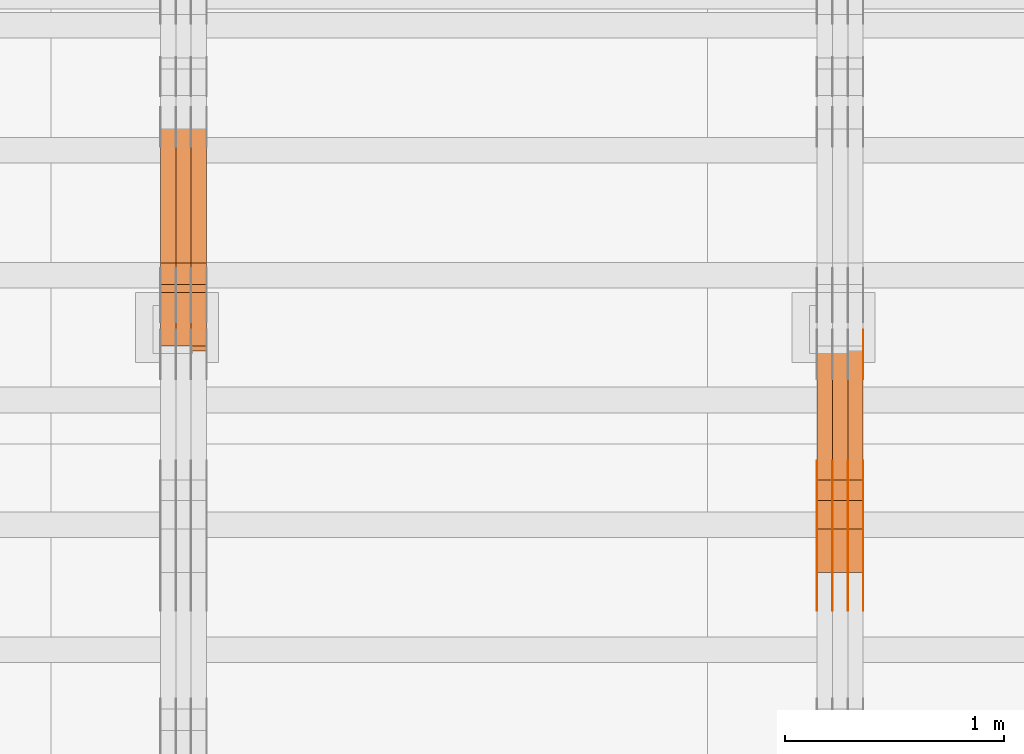
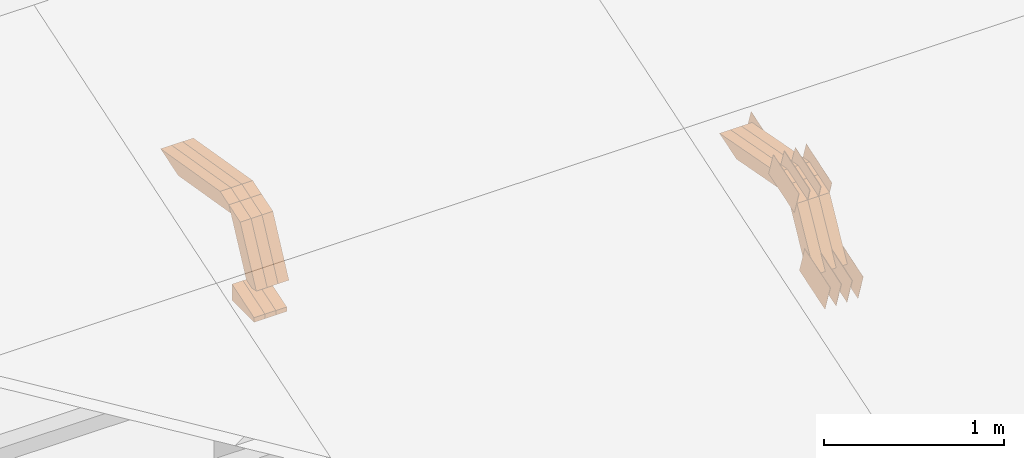
# One storey, part 154 of 385: 28 proxies.
"""IFC2X3 building model written with IfcOpenShell, lengths in millimetres."""

from ifc_helpers import new_model, entity, si_unit, converted_unit, derived_unit, direction, frame, origin, place, context, subcontext, project, spatial, polyline, outline, extrude, source, transform, mapped, material, type_object, type_shapes, element, save


model = new_model("IFC2X3")

# Units and contexts
model_context = context("Model", 3, precision=0.01, world=origin(), true_north=direction((6.12303176911189e-17, 1.0)))
body_context = subcontext(model_context, "Body", "Model", "MODEL_VIEW")
ifc_project = project(units=[si_unit("LENGTHUNIT", "METRE", prefix="MILLI"), si_unit("AREAUNIT", "SQUARE_METRE"), si_unit("VOLUMEUNIT", "CUBIC_METRE"), converted_unit("PLANEANGLEUNIT", "DEGREE", entity("IfcRatioMeasure", 0.0174532925199433), si_unit("PLANEANGLEUNIT", "RADIAN"), dimensions=[0, 0, 0, 0, 0, 0, 0]), si_unit("MASSUNIT", "GRAM", prefix="KILO"), derived_unit("MASSDENSITYUNIT", [(si_unit("MASSUNIT", "GRAM", prefix="KILO"), 1), (si_unit("LENGTHUNIT", "METRE"), -3)]), si_unit("TIMEUNIT", "SECOND"), si_unit("FREQUENCYUNIT", "HERTZ"), si_unit("THERMODYNAMICTEMPERATUREUNIT", "DEGREE_CELSIUS"), derived_unit("THERMALTRANSMITTANCEUNIT", [(si_unit("MASSUNIT", "GRAM", prefix="KILO"), 1), (si_unit("THERMODYNAMICTEMPERATUREUNIT", "KELVIN"), -1), (si_unit("TIMEUNIT", "SECOND"), -3)]), derived_unit("VOLUMETRICFLOWRATEUNIT", [(si_unit("LENGTHUNIT", "METRE"), 3), (si_unit("TIMEUNIT", "SECOND"), -1)]), si_unit("ELECTRICCURRENTUNIT", "AMPERE"), si_unit("ELECTRICVOLTAGEUNIT", "VOLT"), si_unit("POWERUNIT", "WATT"), si_unit("FORCEUNIT", "NEWTON", prefix="KILO"), si_unit("ILLUMINANCEUNIT", "LUX"), si_unit("LUMINOUSFLUXUNIT", "LUMEN"), si_unit("LUMINOUSINTENSITYUNIT", "CANDELA"), derived_unit("USERDEFINED", [(si_unit("MASSUNIT", "GRAM", prefix="KILO"), -1), (si_unit("LENGTHUNIT", "METRE"), -2), (si_unit("TIMEUNIT", "SECOND"), 3), (si_unit("LUMINOUSFLUXUNIT", "LUMEN"), 1)]), derived_unit("LINEARVELOCITYUNIT", [(si_unit("LENGTHUNIT", "METRE"), 1), (si_unit("TIMEUNIT", "SECOND"), -1)]), si_unit("PRESSUREUNIT", "PASCAL"), derived_unit("USERDEFINED", [(si_unit("LENGTHUNIT", "METRE"), -2), (si_unit("MASSUNIT", "GRAM", prefix="KILO"), 1), (si_unit("TIMEUNIT", "SECOND"), -2)])], contexts=[model_context])

# Site, building, storey
site_placement = place(None, origin())
site = spatial("IfcSite", under=ifc_project, at=site_placement, CompositionType="ELEMENT")
building_placement = place(site_placement, origin())
building = spatial("IfcBuilding", under=site, at=building_placement, CompositionType="ELEMENT")
storey_placement = place(building_placement, origin())
storey = spatial("IfcBuildingStorey", under=building, at=storey_placement, Name="Default", CompositionType="ELEMENT", Elevation=0.0)

# Proxies
ifc_material_1 = material(Name="IfcSurfaceStyle #346184")
building_element_proxy_type_1 = type_object("IfcBuildingElementProxyType", PredefinedType="NOTDEFINED", material=ifc_material_1)
shared_shape_1 = source(origin(), body_context, "Body", "SweptSolid", [
    extrude(outline(polyline([(-149.99966632326, -95.9999759039407), (149.999881095801, -95.9999759039407), (150.000557367591, 95.9999759039407), (-150.000772140132, 95.9999759039406), (-149.99966632326, -95.9999759039407)])), frame((150.000557367591, 96.0004291135906, 0.0), z_axis=(0.0, 0.0, 1.0), x_axis=(-1.0, 0.0, 0.0)), (0.0, 0.0, 1.0), 1.29999999999999),
])
type_shapes(building_element_proxy_type_1, [shared_shape_1])
proxy_1_placement = place(building_placement, frame((27386.3, 10934.7734375, 2766.8759765625), z_axis=(-1.0, 0.0, 0.0), x_axis=(0.0, 0.951056516295124, 0.309016994375039)))
element("IfcBuildingElementProxy", 1, at=proxy_1_placement, inside=storey, type_object=building_element_proxy_type_1, material=ifc_material_1, context=body_context, shape_type="MappedRepresentation", body=[
    mapped(shared_shape_1, transform((0.0, 0.0, 0.0), scale=1.0)),
])
ifc_material_2 = material(Name="IfcSurfaceStyle #346127")
building_element_proxy_type_2 = type_object("IfcBuildingElementProxyType", PredefinedType="NOTDEFINED", material=ifc_material_2)
shared_shape_2 = source(origin(), body_context, "Body", "SweptSolid", [
    extrude(outline(polyline([(-149.99966632326, -95.9999759039407), (149.999881095801, -95.9999759039407), (150.000557367591, 95.9999759039407), (-150.000772140132, 95.9999759039406), (-149.99966632326, -95.9999759039407)])), frame((150.000557367591, 96.0004291135906, 0.0), z_axis=(0.0, 0.0, 1.0), x_axis=(-1.0, 0.0, 0.0)), (0.0, 0.0, 1.0), 1.29999999999999),
])
type_shapes(building_element_proxy_type_2, [shared_shape_2])
proxy_2_placement = place(building_placement, frame((27315.0, 10934.7734375, 2766.8759765625), z_axis=(-1.0, 0.0, 0.0), x_axis=(0.0, 0.951056516295124, 0.309016994375039)))
element("IfcBuildingElementProxy", 2, at=proxy_2_placement, inside=storey, type_object=building_element_proxy_type_2, material=ifc_material_2, context=body_context, shape_type="MappedRepresentation", body=[
    mapped(shared_shape_2, transform((0.0, 0.0, 0.0), scale=1.0)),
])
ifc_material_3 = material(Name="IfcSurfaceStyle #346070")
building_element_proxy_type_3 = type_object("IfcBuildingElementProxyType", PredefinedType="NOTDEFINED", material=ifc_material_3)
shared_shape_3 = source(origin(), body_context, "Body", "SweptSolid", [
    extrude(outline(polyline([(-149.99966632326, -95.9999759039407), (149.999881095801, -95.9999759039407), (150.000557367591, 95.9999759039407), (-150.000772140132, 95.9999759039406), (-149.99966632326, -95.9999759039407)])), frame((150.000557367591, 96.0004291135906, 0.0), z_axis=(0.0, 0.0, 1.0), x_axis=(-1.0, 0.0, 0.0)), (0.0, 0.0, 1.0), 1.29999999999999),
])
type_shapes(building_element_proxy_type_3, [shared_shape_3])
proxy_3_placement = place(building_placement, frame((27316.3, 10934.7734375, 2766.8759765625), z_axis=(-1.0, 0.0, 0.0), x_axis=(0.0, 0.951056516295124, 0.309016994375039)))
element("IfcBuildingElementProxy", 3, at=proxy_3_placement, inside=storey, type_object=building_element_proxy_type_3, material=ifc_material_3, context=body_context, shape_type="MappedRepresentation", body=[
    mapped(shared_shape_3, transform((0.0, 0.0, 0.0), scale=1.0)),
])
ifc_material_4 = material(Name="IfcSurfaceStyle #346013")
building_element_proxy_type_4 = type_object("IfcBuildingElementProxyType", PredefinedType="NOTDEFINED", material=ifc_material_4)
shared_shape_4 = source(origin(), body_context, "Body", "SweptSolid", [
    extrude(outline(polyline([(-149.99966632326, -95.9999759039407), (149.999881095801, -95.9999759039407), (150.000557367591, 95.9999759039407), (-150.000772140132, 95.9999759039406), (-149.99966632326, -95.9999759039407)])), frame((150.000557367591, 96.0004291135906, 0.0), z_axis=(0.0, 0.0, 1.0), x_axis=(-1.0, 0.0, 0.0)), (0.0, 0.0, 1.0), 1.29999999999998),
])
type_shapes(building_element_proxy_type_4, [shared_shape_4])
proxy_4_placement = place(building_placement, frame((27245.0, 10934.7734375, 2766.8759765625), z_axis=(-1.0, 0.0, 0.0), x_axis=(0.0, 0.951056516295124, 0.309016994375039)))
element("IfcBuildingElementProxy", 4, at=proxy_4_placement, inside=storey, type_object=building_element_proxy_type_4, material=ifc_material_4, context=body_context, shape_type="MappedRepresentation", body=[
    mapped(shared_shape_4, transform((0.0, 0.0, 0.0), scale=1.0)),
])
ifc_material_5 = material(Name="IfcSurfaceStyle #345956")
building_element_proxy_type_5 = type_object("IfcBuildingElementProxyType", PredefinedType="NOTDEFINED", material=ifc_material_5)
shared_shape_5 = source(origin(), body_context, "Body", "SweptSolid", [
    extrude(outline(polyline([(-149.99966632326, -95.9999759039407), (149.999881095801, -95.9999759039407), (150.000557367591, 95.9999759039407), (-150.000772140132, 95.9999759039406), (-149.99966632326, -95.9999759039407)])), frame((150.000557367591, 96.0004291135906, 0.0), z_axis=(0.0, 0.0, 1.0), x_axis=(-1.0, 0.0, 0.0)), (0.0, 0.0, 1.0), 1.29999999999998),
])
type_shapes(building_element_proxy_type_5, [shared_shape_5])
proxy_5_placement = place(building_placement, frame((27246.3, 10934.7734375, 2766.8759765625), z_axis=(-1.0, 0.0, 0.0), x_axis=(0.0, 0.951056516295124, 0.309016994375039)))
element("IfcBuildingElementProxy", 5, at=proxy_5_placement, inside=storey, type_object=building_element_proxy_type_5, material=ifc_material_5, context=body_context, shape_type="MappedRepresentation", body=[
    mapped(shared_shape_5, transform((0.0, 0.0, 0.0), scale=1.0)),
])
ifc_material_6 = material(Name="IfcSurfaceStyle #345899")
building_element_proxy_type_6 = type_object("IfcBuildingElementProxyType", PredefinedType="NOTDEFINED", material=ifc_material_6)
shared_shape_6 = source(origin(), body_context, "Body", "SweptSolid", [
    extrude(outline(polyline([(-149.99966632326, -95.9999759039407), (149.999881095801, -95.9999759039407), (150.000557367591, 95.9999759039407), (-150.000772140132, 95.9999759039406), (-149.99966632326, -95.9999759039407)])), frame((150.000557367591, 96.0004291135906, 0.0), z_axis=(0.0, 0.0, 1.0), x_axis=(-1.0, 0.0, 0.0)), (0.0, 0.0, 1.0), 1.29999999999998),
])
type_shapes(building_element_proxy_type_6, [shared_shape_6])
proxy_6_placement = place(building_placement, frame((27175.0, 10934.7734375, 2766.8759765625), z_axis=(-1.0, 0.0, 0.0), x_axis=(0.0, 0.951056516295124, 0.309016994375039)))
element("IfcBuildingElementProxy", 6, at=proxy_6_placement, inside=storey, type_object=building_element_proxy_type_6, material=ifc_material_6, context=body_context, shape_type="MappedRepresentation", body=[
    mapped(shared_shape_6, transform((0.0, 0.0, 0.0), scale=1.0)),
])
ifc_material_7 = material(Name="IfcSurfaceStyle #344816")
building_element_proxy_type_7 = type_object("IfcBuildingElementProxyType", PredefinedType="NOTDEFINED", material=ifc_material_7)
shared_shape_7 = source(origin(), body_context, "Body", "SweptSolid", [
    extrude(outline(polyline([(-99.9997874178038, -60.0000528641967), (99.9998102700997, -60.0000528641967), (99.9998251396068, 60.0000528641967), (-99.9998479919027, 60.0000528641967), (-99.9997874178038, -60.0000528641967)])), frame((99.9999918898597, 60.0000528641967, 0.0), z_axis=(0.0, 0.0, 1.0), x_axis=(-1.0, 0.0, 0.0)), (0.0, 0.0, 1.0), 1.3),
])
type_shapes(building_element_proxy_type_7, [shared_shape_7])
proxy_7_placement = place(building_placement, frame((27386.3, 11991.9568177725, 3072.52282247925), z_axis=(-1.0, 0.0, 0.0), x_axis=(0.0, 0.951056516295124, 0.309016994375039)))
element("IfcBuildingElementProxy", 7, at=proxy_7_placement, inside=storey, type_object=building_element_proxy_type_7, material=ifc_material_7, context=body_context, shape_type="MappedRepresentation", body=[
    mapped(shared_shape_7, transform((0.0, 0.0, 0.0), scale=1.0)),
])
ifc_material_8 = material(Name="IfcSurfaceStyle #336608")
building_element_proxy_type_8 = type_object("IfcBuildingElementProxyType", PredefinedType="NOTDEFINED", material=ifc_material_8)
shared_shape_8 = source(origin(), body_context, "Body", "SweptSolid", [
    extrude(outline(polyline([(-150.000273478628, -84.0002987844282), (149.999198496832, -84.0002987844282), (150.000273478627, 84.0002987844282), (-149.999198496831, 84.0002987844282), (-150.000273478628, -84.0002987844282)])), frame((150.000273478627, 84.0002987844282, 0.0), z_axis=(0.0, 0.0, 1.0), x_axis=(-1.0, 0.0, 0.0)), (0.0, 0.0, 1.0), 1.29999999999999),
])
type_shapes(building_element_proxy_type_8, [shared_shape_8])
proxy_8_placement = place(building_placement, frame((27386.3, 11283.0116722926, 3194.09682266857), z_axis=(-1.0, 0.0, 0.0), x_axis=(0.0, 0.951056516295154, 0.309016994374948)))
element("IfcBuildingElementProxy", 8, at=proxy_8_placement, inside=storey, type_object=building_element_proxy_type_8, material=ifc_material_8, context=body_context, shape_type="MappedRepresentation", body=[
    mapped(shared_shape_8, transform((0.0, 0.0, 0.0), scale=1.0)),
])
ifc_material_9 = material(Name="IfcSurfaceStyle #336551")
building_element_proxy_type_9 = type_object("IfcBuildingElementProxyType", PredefinedType="NOTDEFINED", material=ifc_material_9)
shared_shape_9 = source(origin(), body_context, "Body", "SweptSolid", [
    extrude(outline(polyline([(-150.000273478628, -84.0002987844282), (149.999198496832, -84.0002987844282), (150.000273478627, 84.0002987844282), (-149.999198496831, 84.0002987844282), (-150.000273478628, -84.0002987844282)])), frame((150.000273478627, 84.0002987844282, 0.0), z_axis=(0.0, 0.0, 1.0), x_axis=(-1.0, 0.0, 0.0)), (0.0, 0.0, 1.0), 1.29999999999999),
])
type_shapes(building_element_proxy_type_9, [shared_shape_9])
proxy_9_placement = place(building_placement, frame((27315.0, 11283.0116722926, 3194.09682266857), z_axis=(-1.0, 0.0, 0.0), x_axis=(0.0, 0.951056516295154, 0.309016994374948)))
element("IfcBuildingElementProxy", 9, at=proxy_9_placement, inside=storey, type_object=building_element_proxy_type_9, material=ifc_material_9, context=body_context, shape_type="MappedRepresentation", body=[
    mapped(shared_shape_9, transform((0.0, 0.0, 0.0), scale=1.0)),
])
ifc_material_10 = material(Name="IfcSurfaceStyle #336494")
building_element_proxy_type_10 = type_object("IfcBuildingElementProxyType", PredefinedType="NOTDEFINED", material=ifc_material_10)
shared_shape_10 = source(origin(), body_context, "Body", "SweptSolid", [
    extrude(outline(polyline([(-150.000273478628, -84.0002987844282), (149.999198496832, -84.0002987844282), (150.000273478627, 84.0002987844282), (-149.999198496831, 84.0002987844282), (-150.000273478628, -84.0002987844282)])), frame((150.000273478627, 84.0002987844282, 0.0), z_axis=(0.0, 0.0, 1.0), x_axis=(-1.0, 0.0, 0.0)), (0.0, 0.0, 1.0), 1.29999999999999),
])
type_shapes(building_element_proxy_type_10, [shared_shape_10])
proxy_10_placement = place(building_placement, frame((27316.3, 11283.0116722926, 3194.09682266857), z_axis=(-1.0, 0.0, 0.0), x_axis=(0.0, 0.951056516295154, 0.309016994374948)))
element("IfcBuildingElementProxy", 10, at=proxy_10_placement, inside=storey, type_object=building_element_proxy_type_10, material=ifc_material_10, context=body_context, shape_type="MappedRepresentation", body=[
    mapped(shared_shape_10, transform((0.0, 0.0, 0.0), scale=1.0)),
])
ifc_material_11 = material(Name="IfcSurfaceStyle #336437")
building_element_proxy_type_11 = type_object("IfcBuildingElementProxyType", PredefinedType="NOTDEFINED", material=ifc_material_11)
shared_shape_11 = source(origin(), body_context, "Body", "SweptSolid", [
    extrude(outline(polyline([(-150.000273478628, -84.0002987844282), (149.999198496832, -84.0002987844282), (150.000273478627, 84.0002987844282), (-149.999198496831, 84.0002987844282), (-150.000273478628, -84.0002987844282)])), frame((150.000273478627, 84.0002987844282, 0.0), z_axis=(0.0, 0.0, 1.0), x_axis=(-1.0, 0.0, 0.0)), (0.0, 0.0, 1.0), 1.29999999999998),
])
type_shapes(building_element_proxy_type_11, [shared_shape_11])
proxy_11_placement = place(building_placement, frame((27245.0, 11283.0116722926, 3194.09682266857), z_axis=(-1.0, 0.0, 0.0), x_axis=(0.0, 0.951056516295154, 0.309016994374948)))
element("IfcBuildingElementProxy", 11, at=proxy_11_placement, inside=storey, type_object=building_element_proxy_type_11, material=ifc_material_11, context=body_context, shape_type="MappedRepresentation", body=[
    mapped(shared_shape_11, transform((0.0, 0.0, 0.0), scale=1.0)),
])
ifc_material_12 = material(Name="IfcSurfaceStyle #336380")
building_element_proxy_type_12 = type_object("IfcBuildingElementProxyType", PredefinedType="NOTDEFINED", material=ifc_material_12)
shared_shape_12 = source(origin(), body_context, "Body", "SweptSolid", [
    extrude(outline(polyline([(-150.000273478628, -84.0002987844282), (149.999198496832, -84.0002987844282), (150.000273478627, 84.0002987844282), (-149.999198496831, 84.0002987844282), (-150.000273478628, -84.0002987844282)])), frame((150.000273478627, 84.0002987844282, 0.0), z_axis=(0.0, 0.0, 1.0), x_axis=(-1.0, 0.0, 0.0)), (0.0, 0.0, 1.0), 1.29999999999998),
])
type_shapes(building_element_proxy_type_12, [shared_shape_12])
proxy_12_placement = place(building_placement, frame((27246.3, 11283.0116722926, 3194.09682266857), z_axis=(-1.0, 0.0, 0.0), x_axis=(0.0, 0.951056516295154, 0.309016994374948)))
element("IfcBuildingElementProxy", 12, at=proxy_12_placement, inside=storey, type_object=building_element_proxy_type_12, material=ifc_material_12, context=body_context, shape_type="MappedRepresentation", body=[
    mapped(shared_shape_12, transform((0.0, 0.0, 0.0), scale=1.0)),
])
ifc_material_13 = material(Name="IfcSurfaceStyle #336323")
building_element_proxy_type_13 = type_object("IfcBuildingElementProxyType", PredefinedType="NOTDEFINED", material=ifc_material_13)
shared_shape_13 = source(origin(), body_context, "Body", "SweptSolid", [
    extrude(outline(polyline([(-150.000273478628, -84.0002987844282), (149.999198496832, -84.0002987844282), (150.000273478627, 84.0002987844282), (-149.999198496831, 84.0002987844282), (-150.000273478628, -84.0002987844282)])), frame((150.000273478627, 84.0002987844282, 0.0), z_axis=(0.0, 0.0, 1.0), x_axis=(-1.0, 0.0, 0.0)), (0.0, 0.0, 1.0), 1.29999999999998),
])
type_shapes(building_element_proxy_type_13, [shared_shape_13])
proxy_13_placement = place(building_placement, frame((27175.0, 11283.0116722926, 3194.09682266857), z_axis=(-1.0, 0.0, 0.0), x_axis=(0.0, 0.951056516295154, 0.309016994374948)))
element("IfcBuildingElementProxy", 13, at=proxy_13_placement, inside=storey, type_object=building_element_proxy_type_13, material=ifc_material_13, context=body_context, shape_type="MappedRepresentation", body=[
    mapped(shared_shape_13, transform((0.0, 0.0, 0.0), scale=1.0)),
])
ifc_material_14 = material(Name="IfcSurfaceStyle #326312")
building_element_proxy_type_14 = type_object("IfcBuildingElementProxyType", Name="T1-W9 326310", PredefinedType="NOTDEFINED", material=ifc_material_14)
shared_shape_14 = source(origin(), body_context, "Body", "SweptSolid", [
    extrude(outline(polyline([(-287.457507623288, -47.5000268597988), (288.590479960635, -47.5000268597988), (273.55062971372, -2.33146189358546e-05), (186.625054999886, 47.5000385171083), (-461.308657050953, 47.5000385171083), (-287.457507623288, -47.5000268597988)])), frame((288.590945855618, 47.5000968036551, 0.0), z_axis=(0.0, 0.0, 1.0), x_axis=(-1.0, 0.0, 0.0)), (0.0, 0.0, 1.0), 70.0),
])
type_shapes(building_element_proxy_type_14, [shared_shape_14])
proxy_14_placement = place(building_placement, frame((27385.0, 11432.1200855376, 3205.63308612017), z_axis=(-1.0, 0.0, 0.0), x_axis=(0.0, 0.982760503514031, -0.184883186722992)))
element("IfcBuildingElementProxy", 14, at=proxy_14_placement, inside=storey, type_object=building_element_proxy_type_14, material=ifc_material_14, Name="T1-W9", context=body_context, shape_type="MappedRepresentation", body=[
    mapped(shared_shape_14, transform((0.0, 0.0, 0.0), scale=1.0)),
])
ifc_material_15 = material(Name="IfcSurfaceStyle #326246")
building_element_proxy_type_15 = type_object("IfcBuildingElementProxyType", Name="T1-W9 326244", PredefinedType="NOTDEFINED", material=ifc_material_15)
shared_shape_15 = source(origin(), body_context, "Body", "SweptSolid", [
    extrude(outline(polyline([(-287.457507623288, -47.5000268597988), (288.590479960635, -47.5000268597988), (273.55062971372, -2.33146189358546e-05), (186.625054999886, 47.5000385171083), (-461.308657050953, 47.5000385171083), (-287.457507623288, -47.5000268597988)])), frame((288.590945855618, 47.5000968036551, 0.0), z_axis=(0.0, 0.0, 1.0), x_axis=(-1.0, 0.0, 0.0)), (0.0, 0.0, 1.0), 70.0),
])
type_shapes(building_element_proxy_type_15, [shared_shape_15])
proxy_15_placement = place(building_placement, frame((27315.0, 11432.1200855376, 3205.63308612017), z_axis=(-1.0, 0.0, 0.0), x_axis=(0.0, 0.982760503514031, -0.184883186722992)))
element("IfcBuildingElementProxy", 15, at=proxy_15_placement, inside=storey, type_object=building_element_proxy_type_15, material=ifc_material_15, Name="T1-W9", context=body_context, shape_type="MappedRepresentation", body=[
    mapped(shared_shape_15, transform((0.0, 0.0, 0.0), scale=1.0)),
])
ifc_material_16 = material(Name="IfcSurfaceStyle #326180")
building_element_proxy_type_16 = type_object("IfcBuildingElementProxyType", Name="T1-W9 326178", PredefinedType="NOTDEFINED", material=ifc_material_16)
shared_shape_16 = source(origin(), body_context, "Body", "SweptSolid", [
    extrude(outline(polyline([(-287.457507623288, -47.5000268597988), (288.590479960635, -47.5000268597988), (273.55062971372, -2.33146189358546e-05), (186.625054999886, 47.5000385171083), (-461.308657050953, 47.5000385171083), (-287.457507623288, -47.5000268597988)])), frame((288.590945855618, 47.5000968036551, 0.0), z_axis=(0.0, 0.0, 1.0), x_axis=(-1.0, 0.0, 0.0)), (0.0, 0.0, 1.0), 70.0),
])
type_shapes(building_element_proxy_type_16, [shared_shape_16])
proxy_16_placement = place(building_placement, frame((27245.0, 11432.1200855376, 3205.63308612017), z_axis=(-1.0, 0.0, 0.0), x_axis=(0.0, 0.982760503514031, -0.184883186722992)))
element("IfcBuildingElementProxy", 16, at=proxy_16_placement, inside=storey, type_object=building_element_proxy_type_16, material=ifc_material_16, Name="T1-W9", context=body_context, shape_type="MappedRepresentation", body=[
    mapped(shared_shape_16, transform((0.0, 0.0, 0.0), scale=1.0)),
])
ifc_material_17 = material(Name="IfcSurfaceStyle #325916")
building_element_proxy_type_17 = type_object("IfcBuildingElementProxyType", Name="T1-W32 325914", PredefinedType="NOTDEFINED", material=ifc_material_17)
shared_shape_17 = source(origin(), body_context, "Body", "SweptSolid", [
    extrude(outline(polyline([(-312.414547135921, -47.5000544873059), (136.677011757652, -47.5000544873059), (186.250996577889, 0.000369497452627243), (202.753116295831, 47.4998697385796), (-213.26657749545, 47.4998697385796), (-312.414547135921, -47.5000544873059)])), frame((202.753376481939, 47.5001296985553, 0.0), z_axis=(0.0, 0.0, 1.0), x_axis=(-1.0, 0.0, 0.0)), (0.0, 0.0, 1.0), 70.0),
])
type_shapes(building_element_proxy_type_17, [shared_shape_17])
proxy_17_placement = place(building_placement, frame((27385.0, 11110.7808979007, 2747.18129017315), z_axis=(-1.0, 0.0, 0.0), x_axis=(0.0, 0.472919689385906, 0.881105537033526)))
element("IfcBuildingElementProxy", 17, at=proxy_17_placement, inside=storey, type_object=building_element_proxy_type_17, material=ifc_material_17, Name="T1-W32", context=body_context, shape_type="MappedRepresentation", body=[
    mapped(shared_shape_17, transform((0.0, 0.0, 0.0), scale=1.0)),
])
ifc_material_18 = material(Name="IfcSurfaceStyle #325850")
building_element_proxy_type_18 = type_object("IfcBuildingElementProxyType", Name="T1-W32 325848", PredefinedType="NOTDEFINED", material=ifc_material_18)
shared_shape_18 = source(origin(), body_context, "Body", "SweptSolid", [
    extrude(outline(polyline([(-312.414547135921, -47.5000544873059), (136.677011757652, -47.5000544873059), (186.250996577889, 0.000369497452627243), (202.753116295831, 47.4998697385796), (-213.26657749545, 47.4998697385796), (-312.414547135921, -47.5000544873059)])), frame((202.753376481939, 47.5001296985553, 0.0), z_axis=(0.0, 0.0, 1.0), x_axis=(-1.0, 0.0, 0.0)), (0.0, 0.0, 1.0), 70.0),
])
type_shapes(building_element_proxy_type_18, [shared_shape_18])
proxy_18_placement = place(building_placement, frame((27315.0, 11110.7808979007, 2747.18129017315), z_axis=(-1.0, 0.0, 0.0), x_axis=(0.0, 0.472919689385906, 0.881105537033526)))
element("IfcBuildingElementProxy", 18, at=proxy_18_placement, inside=storey, type_object=building_element_proxy_type_18, material=ifc_material_18, Name="T1-W32", context=body_context, shape_type="MappedRepresentation", body=[
    mapped(shared_shape_18, transform((0.0, 0.0, 0.0), scale=1.0)),
])
ifc_material_19 = material(Name="IfcSurfaceStyle #325784")
building_element_proxy_type_19 = type_object("IfcBuildingElementProxyType", Name="T1-W32 325782", PredefinedType="NOTDEFINED", material=ifc_material_19)
shared_shape_19 = source(origin(), body_context, "Body", "SweptSolid", [
    extrude(outline(polyline([(-312.414547135921, -47.5000544873059), (136.677011757652, -47.5000544873059), (186.250996577889, 0.000369497452627243), (202.753116295831, 47.4998697385796), (-213.26657749545, 47.4998697385796), (-312.414547135921, -47.5000544873059)])), frame((202.753376481939, 47.5001296985553, 0.0), z_axis=(0.0, 0.0, 1.0), x_axis=(-1.0, 0.0, 0.0)), (0.0, 0.0, 1.0), 70.0),
])
type_shapes(building_element_proxy_type_19, [shared_shape_19])
proxy_19_placement = place(building_placement, frame((27245.0, 11110.7808979007, 2747.18129017315), z_axis=(-1.0, 0.0, 0.0), x_axis=(0.0, 0.472919689385906, 0.881105537033526)))
element("IfcBuildingElementProxy", 19, at=proxy_19_placement, inside=storey, type_object=building_element_proxy_type_19, material=ifc_material_19, Name="T1-W32", context=body_context, shape_type="MappedRepresentation", body=[
    mapped(shared_shape_19, transform((0.0, 0.0, 0.0), scale=1.0)),
])
ifc_material_20 = material(Name="IfcSurfaceStyle #294400")
building_element_proxy_type_20 = type_object("IfcBuildingElementProxyType", Name="T1-E1 294398", PredefinedType="NOTDEFINED", material=ifc_material_20)
shared_shape_20 = source(origin(), body_context, "Body", "SweptSolid", [
    extrude(outline(polyline([(-75.1378173828004, -122.500000000005), (35.3350830078246, -122.500000000005), (35.3350830078004, 122.500000000005), (4.46765136717545, 122.500000000005), (-75.1378173828004, -122.500000000005)])), frame((35.3350830078246, 122.500000104877, 0.0), z_axis=(0.0, 0.0, 1.0), x_axis=(-1.0, 0.0, 0.0)), (0.0, 0.0, 1.0), 70.0),
])
type_shapes(building_element_proxy_type_20, [shared_shape_20])
proxy_20_placement = place(building_placement, frame((24385.0, 12145.0, 2849.54565429685), z_axis=(-1.0, 0.0, 0.0), x_axis=(0.0, 0.0, 1.0)))
element("IfcBuildingElementProxy", 20, at=proxy_20_placement, inside=storey, type_object=building_element_proxy_type_20, material=ifc_material_20, Name="T1-E1", context=body_context, shape_type="MappedRepresentation", body=[
    mapped(shared_shape_20, transform((0.0, 0.0, 0.0), scale=1.0)),
])
ifc_material_21 = material(Name="IfcSurfaceStyle #294343")
building_element_proxy_type_21 = type_object("IfcBuildingElementProxyType", Name="T1-E1 294341", PredefinedType="NOTDEFINED", material=ifc_material_21)
shared_shape_21 = source(origin(), body_context, "Body", "SweptSolid", [
    extrude(outline(polyline([(-75.1378173828004, -122.500000000005), (35.3350830078246, -122.500000000005), (35.3350830078004, 122.500000000005), (4.46765136717545, 122.500000000005), (-75.1378173828004, -122.500000000005)])), frame((35.3350830078246, 122.500000104877, 0.0), z_axis=(0.0, 0.0, 1.0), x_axis=(-1.0, 0.0, 0.0)), (0.0, 0.0, 1.0), 70.0),
])
type_shapes(building_element_proxy_type_21, [shared_shape_21])
proxy_21_placement = place(building_placement, frame((24315.0, 12145.0, 2849.54565429685), z_axis=(-1.0, 0.0, 0.0), x_axis=(0.0, 0.0, 1.0)))
element("IfcBuildingElementProxy", 21, at=proxy_21_placement, inside=storey, type_object=building_element_proxy_type_21, material=ifc_material_21, Name="T1-E1", context=body_context, shape_type="MappedRepresentation", body=[
    mapped(shared_shape_21, transform((0.0, 0.0, 0.0), scale=1.0)),
])
ifc_material_22 = material(Name="IfcSurfaceStyle #294286")
building_element_proxy_type_22 = type_object("IfcBuildingElementProxyType", Name="T1-E1 294284", PredefinedType="NOTDEFINED", material=ifc_material_22)
shared_shape_22 = source(origin(), body_context, "Body", "SweptSolid", [
    extrude(outline(polyline([(-75.1378173828004, -122.500000000005), (35.3350830078246, -122.500000000005), (35.3350830078004, 122.500000000005), (4.46765136717545, 122.500000000005), (-75.1378173828004, -122.500000000005)])), frame((35.3350830078246, 122.500000104877, 0.0), z_axis=(0.0, 0.0, 1.0), x_axis=(-1.0, 0.0, 0.0)), (0.0, 0.0, 1.0), 70.0),
])
type_shapes(building_element_proxy_type_22, [shared_shape_22])
proxy_22_placement = place(building_placement, frame((24245.0, 12145.0, 2849.54565429685), z_axis=(-1.0, 0.0, 0.0), x_axis=(0.0, 0.0, 1.0)))
element("IfcBuildingElementProxy", 22, at=proxy_22_placement, inside=storey, type_object=building_element_proxy_type_22, material=ifc_material_22, Name="T1-E1", context=body_context, shape_type="MappedRepresentation", body=[
    mapped(shared_shape_22, transform((0.0, 0.0, 0.0), scale=1.0)),
])
ifc_material_23 = material(Name="IfcSurfaceStyle #292672")
building_element_proxy_type_23 = type_object("IfcBuildingElementProxyType", Name="T1-W7 292670", PredefinedType="NOTDEFINED", material=ifc_material_23)
shared_shape_23 = source(origin(), body_context, "Body", "SweptSolid", [
    extrude(outline(polyline([(-296.174043820986, -47.5000676566704), (297.841254477443, -47.5000676566704), (283.518570346415, -7.10254316533821e-06), (192.674144473719, 47.500071207942), (-477.859925476591, 47.500071207942), (-296.174043820986, -47.5000676566704)])), frame((297.841254477443, 47.5000816097442, 0.0), z_axis=(0.0, 0.0, 1.0), x_axis=(-1.0, 0.0, 0.0)), (0.0, 0.0, 1.0), 70.0),
])
type_shapes(building_element_proxy_type_23, [shared_shape_23])
proxy_23_placement = place(building_placement, frame((24385.0, 12419.2991208897, 3526.2136755972), z_axis=(-1.0, 0.0, 0.0), x_axis=(0.0, 0.985983815111804, -0.166840991178939)))
element("IfcBuildingElementProxy", 23, at=proxy_23_placement, inside=storey, type_object=building_element_proxy_type_23, material=ifc_material_23, Name="T1-W7", context=body_context, shape_type="MappedRepresentation", body=[
    mapped(shared_shape_23, transform((0.0, 0.0, 0.0), scale=1.0)),
])
ifc_material_24 = material(Name="IfcSurfaceStyle #292606")
building_element_proxy_type_24 = type_object("IfcBuildingElementProxyType", Name="T1-W7 292604", PredefinedType="NOTDEFINED", material=ifc_material_24)
shared_shape_24 = source(origin(), body_context, "Body", "SweptSolid", [
    extrude(outline(polyline([(-296.174043820986, -47.5000676566704), (297.841254477443, -47.5000676566704), (283.518570346415, -7.10254316533821e-06), (192.674144473719, 47.500071207942), (-477.859925476591, 47.500071207942), (-296.174043820986, -47.5000676566704)])), frame((297.841254477443, 47.5000816097442, 0.0), z_axis=(0.0, 0.0, 1.0), x_axis=(-1.0, 0.0, 0.0)), (0.0, 0.0, 1.0), 70.0),
])
type_shapes(building_element_proxy_type_24, [shared_shape_24])
proxy_24_placement = place(building_placement, frame((24315.0, 12419.2991208897, 3526.2136755972), z_axis=(-1.0, 0.0, 0.0), x_axis=(0.0, 0.985983815111804, -0.166840991178939)))
element("IfcBuildingElementProxy", 24, at=proxy_24_placement, inside=storey, type_object=building_element_proxy_type_24, material=ifc_material_24, Name="T1-W7", context=body_context, shape_type="MappedRepresentation", body=[
    mapped(shared_shape_24, transform((0.0, 0.0, 0.0), scale=1.0)),
])
ifc_material_25 = material(Name="IfcSurfaceStyle #292540")
building_element_proxy_type_25 = type_object("IfcBuildingElementProxyType", Name="T1-W7 292538", PredefinedType="NOTDEFINED", material=ifc_material_25)
shared_shape_25 = source(origin(), body_context, "Body", "SweptSolid", [
    extrude(outline(polyline([(-296.174043820986, -47.5000676566704), (297.841254477443, -47.5000676566704), (283.518570346415, -7.10254316533821e-06), (192.674144473719, 47.500071207942), (-477.859925476591, 47.500071207942), (-296.174043820986, -47.5000676566704)])), frame((297.841254477443, 47.5000816097442, 0.0), z_axis=(0.0, 0.0, 1.0), x_axis=(-1.0, 0.0, 0.0)), (0.0, 0.0, 1.0), 70.0),
])
type_shapes(building_element_proxy_type_25, [shared_shape_25])
proxy_25_placement = place(building_placement, frame((24245.0, 12419.2991208897, 3526.2136755972), z_axis=(-1.0, 0.0, 0.0), x_axis=(0.0, 0.985983815111804, -0.166840991178939)))
element("IfcBuildingElementProxy", 25, at=proxy_25_placement, inside=storey, type_object=building_element_proxy_type_25, material=ifc_material_25, Name="T1-W7", context=body_context, shape_type="MappedRepresentation", body=[
    mapped(shared_shape_25, transform((0.0, 0.0, 0.0), scale=1.0)),
])
ifc_material_26 = material(Name="IfcSurfaceStyle #292276")
building_element_proxy_type_26 = type_object("IfcBuildingElementProxyType", Name="T1-W36 292274", PredefinedType="NOTDEFINED", material=ifc_material_26)
shared_shape_26 = source(origin(), body_context, "Body", "SweptSolid", [
    extrude(outline(polyline([(-300.714670922549, -47.4998881108849), (134.031527004269, -47.499888110885), (180.52054953879, -0.000136170977331764), (193.89900152221, 47.500563476126), (-207.736407142719, 47.4993489166213), (-300.714670922549, -47.4998881108849)])), frame((193.899145164686, 47.5001861375837, 0.0), z_axis=(0.0, 0.0, 1.0), x_axis=(-1.0, 3.02403492980632e-06, 0.0)), (0.0, 0.0, 1.0), 70.0),
])
type_shapes(building_element_proxy_type_26, [shared_shape_26])
proxy_26_placement = place(building_placement, frame((24385.0, 12120.5935627532, 3076.1128858536), z_axis=(-1.0, 0.0, 0.0), x_axis=(0.0, 0.444384650266842, 0.895836080210669)))
element("IfcBuildingElementProxy", 26, at=proxy_26_placement, inside=storey, type_object=building_element_proxy_type_26, material=ifc_material_26, Name="T1-W36", context=body_context, shape_type="MappedRepresentation", body=[
    mapped(shared_shape_26, transform((0.0, 0.0, 0.0), scale=1.0)),
])
ifc_material_27 = material(Name="IfcSurfaceStyle #292210")
building_element_proxy_type_27 = type_object("IfcBuildingElementProxyType", Name="T1-W36 292208", PredefinedType="NOTDEFINED", material=ifc_material_27)
shared_shape_27 = source(origin(), body_context, "Body", "SweptSolid", [
    extrude(outline(polyline([(-300.714670922549, -47.4998881108849), (134.031527004269, -47.499888110885), (180.52054953879, -0.000136170977331764), (193.89900152221, 47.500563476126), (-207.736407142719, 47.4993489166213), (-300.714670922549, -47.4998881108849)])), frame((193.899145164686, 47.5001861375837, 0.0), z_axis=(0.0, 0.0, 1.0), x_axis=(-1.0, 3.02403492980632e-06, 0.0)), (0.0, 0.0, 1.0), 70.0),
])
type_shapes(building_element_proxy_type_27, [shared_shape_27])
proxy_27_placement = place(building_placement, frame((24315.0, 12120.5935627532, 3076.1128858536), z_axis=(-1.0, 0.0, 0.0), x_axis=(0.0, 0.444384650266842, 0.895836080210669)))
element("IfcBuildingElementProxy", 27, at=proxy_27_placement, inside=storey, type_object=building_element_proxy_type_27, material=ifc_material_27, Name="T1-W36", context=body_context, shape_type="MappedRepresentation", body=[
    mapped(shared_shape_27, transform((0.0, 0.0, 0.0), scale=1.0)),
])
ifc_material_28 = material(Name="IfcSurfaceStyle #292144")
building_element_proxy_type_28 = type_object("IfcBuildingElementProxyType", Name="T1-W36 292142", PredefinedType="NOTDEFINED", material=ifc_material_28)
shared_shape_28 = source(origin(), body_context, "Body", "SweptSolid", [
    extrude(outline(polyline([(-300.714670922549, -47.4998881108849), (134.031527004269, -47.499888110885), (180.52054953879, -0.000136170977331764), (193.89900152221, 47.500563476126), (-207.736407142719, 47.4993489166213), (-300.714670922549, -47.4998881108849)])), frame((193.899145164686, 47.5001861375837, 0.0), z_axis=(0.0, 0.0, 1.0), x_axis=(-1.0, 3.02403492980632e-06, 0.0)), (0.0, 0.0, 1.0), 70.0),
])
type_shapes(building_element_proxy_type_28, [shared_shape_28])
proxy_28_placement = place(building_placement, frame((24245.0, 12120.5935627532, 3076.1128858536), z_axis=(-1.0, 0.0, 0.0), x_axis=(0.0, 0.444384650266842, 0.895836080210669)))
element("IfcBuildingElementProxy", 28, at=proxy_28_placement, inside=storey, type_object=building_element_proxy_type_28, material=ifc_material_28, Name="T1-W36", context=body_context, shape_type="MappedRepresentation", body=[
    mapped(shared_shape_28, transform((0.0, 0.0, 0.0), scale=1.0)),
])

save(model, "model.ifc")
